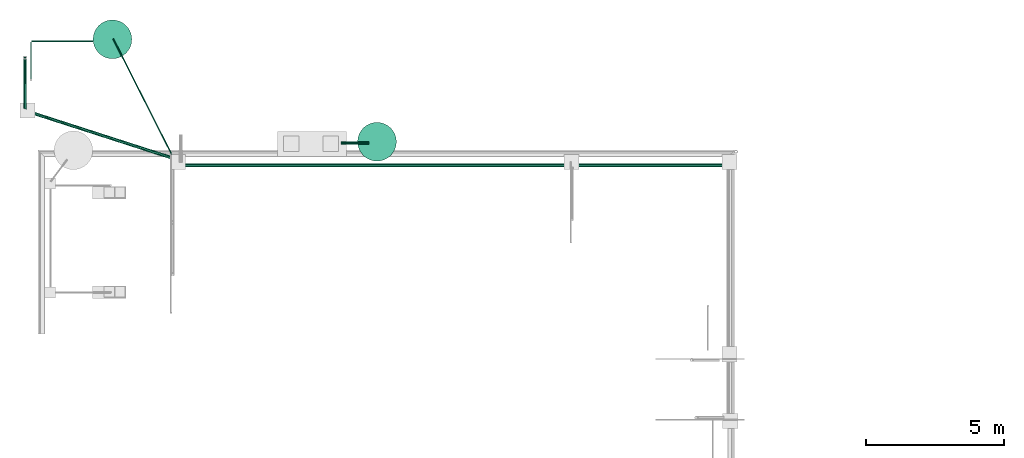
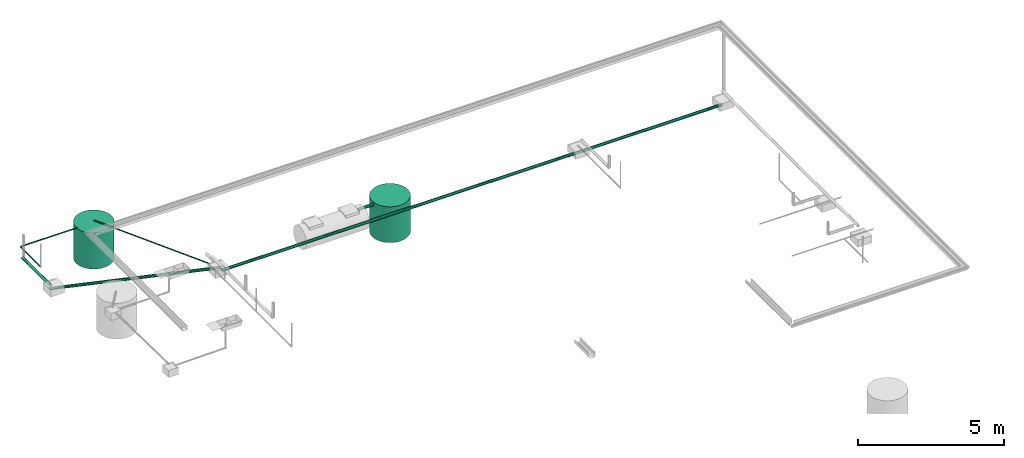
# One storey, part 6 of 15: 7 pipe segments, 2 waste terminals.
"""IFC4X3_ADD2 building model written with IfcOpenShell, lengths in metres."""

from ifc_helpers import new_model, entity, si_unit, converted_unit, frame, origin_with_axes, origin_2d_with_axis, place, context, subcontext, project, spatial, circle, hollow_circle, extrude, clip, halfspace, material, material_profile, profile_set, profile_usage, type_object, element, save


model = new_model("IFC4X3_ADD2")

# Units and contexts
model_context = context("Model", 3, precision=1e-05, world=origin_with_axes())
plan_context = context("Plan", 2, precision=1e-05, world=origin_2d_with_axis())
body_context = subcontext(model_context, "Body", "Model", "MODEL_VIEW")
ifc_project = project(units=[si_unit("VOLUMEUNIT", "CUBIC_METRE"), si_unit("LENGTHUNIT", "METRE"), converted_unit("PLANEANGLEUNIT", "degree", entity("IfcReal", 0.0174532925199433), si_unit("PLANEANGLEUNIT", "RADIAN"), dimensions=[0, 0, 0, 0, 0, 0, 0]), si_unit("AREAUNIT", "SQUARE_METRE")], contexts=[model_context, plan_context])

# Site, building, storey
site_placement = place(None, origin_with_axes())
site = spatial("IfcSite", under=ifc_project, at=site_placement)
building_placement = place(site_placement, origin_with_axes())
building = spatial("IfcBuilding", under=site, at=building_placement, Name="Building")
storey_placement = place(building_placement, origin_with_axes())
storey = spatial("IfcBuildingStorey", under=building, at=storey_placement, Name="Plumbing")

# Waste terminals
ifc_material_1 = material(Name="Wall")
ifc_material_profile_1 = material_profile(ifc_material_1, circle(Radius=0.699999988079071))
ifc_profile_set_1 = profile_set([ifc_material_profile_1])
ifc_profile_usage_1 = profile_usage(ifc_profile_set_1, cardinal=5)
waste_terminal_type = type_object("IfcWasteTerminalType", Name="1200mm ID", PredefinedType="USERDEFINED", material=ifc_profile_set_1)
waste_terminal_1_placement = place(storey_placement, frame((16.6055736541748, 27.7044715881348, -7.45058059692383e-09), z_axis=(-8.74227552571925e-08, 1.50995816738939e-07, -0.999999999999985), x_axis=(1.62920684942943e-07, 0.999999999999975, 1.50995802528083e-07)))
element("IfcWasteTerminal", 1, at=waste_terminal_1_placement, inside=storey, type_object=waste_terminal_type, material=ifc_profile_usage_1, Name="WasteTerminal", context=body_context, shape_type="SweptSolid", body=[
    extrude(circle(Radius=0.699999988079071), origin_with_axes(), (0.0, 0.0, 1.0), 1.5),
])
ifc_profile_usage_2 = profile_usage(ifc_profile_set_1, cardinal=5)
waste_terminal_2_placement = place(storey_placement, frame((7.02344703674316, 31.4147243499756, 1.19209289550781e-07), z_axis=(-1.50995802528084e-07, -8.74227694680472e-08, -0.999999999999985), x_axis=(-0.999999999999985, 8.74227836789019e-08, 1.50995802528084e-07)))
element("IfcWasteTerminal", 2, at=waste_terminal_2_placement, inside=storey, type_object=waste_terminal_type, material=ifc_profile_usage_2, Name="WasteTerminal", context=body_context, shape_type="SweptSolid", body=[
    extrude(circle(Radius=0.699999988079071), origin_with_axes(), (0.0, 0.0, 1.0), 1.5),
])

# Pipe segments
ifc_material_2 = material()
ifc_material_profile_2 = material_profile(ifc_material_2, hollow_circle(Radius=0.0571499988436699, WallThickness=0.012699999846518))
ifc_profile_set_2 = profile_set([ifc_material_profile_2])
ifc_profile_usage_3 = profile_usage(ifc_profile_set_2)
pipe_segment_type_1 = type_object("IfcPipeSegmentType", Name="4inch Tank", PredefinedType="FLEXIBLESEGMENT", material=ifc_profile_set_2)
pipe_segment_1_placement = place(storey_placement, frame((29.2563171386719, 26.8517551422119, -0.1225526034832), z_axis=(-0.999999999999996, 4.37114202611609e-08, 7.5497901264043e-08), x_axis=(-4.37113882867346e-08, -0.999999999999923, 3.89414395840474e-07)))
element("IfcPipeSegment", 3, at=pipe_segment_1_placement, inside=storey, type_object=pipe_segment_type_1, material=ifc_profile_usage_3, Name="PipeSegment", PredefinedType="FLEXIBLESEGMENT", context=body_context, shape_type="SweptSolid", body=[
    extrude(hollow_circle(Radius=0.0571499988436699, WallThickness=0.012699999846518), origin_with_axes(), (0.0, 0.0, 1.0), 19.7956980029457),
])
ifc_profile_usage_4 = profile_usage(ifc_profile_set_2)
pipe_segment_2_placement = place(storey_placement, frame((3.85473585128784, 28.7807121276855, -0.0307567920535803), z_axis=(8.74228121006121e-08, 0.999999999999993, 7.54979012640428e-08), x_axis=(-0.999999999999921, 8.74227765734689e-08, 3.89414424262182e-07)))
element("IfcPipeSegment", 4, at=pipe_segment_2_placement, inside=storey, type_object=pipe_segment_type_1, material=ifc_profile_usage_4, Name="PipeSegment", PredefinedType="FLEXIBLESEGMENT", context=body_context, shape_type="Clipping", body=[
    clip(extrude(hollow_circle(Radius=0.0571499988436699, WallThickness=0.012699999846518), origin_with_axes(), (0.0, 0.0, 1.0), 2.02640719087022), halfspace(frame((0.148413762450218, -0.091795414686203, 0.162123039364815), z_axis=(0.306696087121964, -4.64804941202601e-07, -0.951807498931885), x_axis=(-1.51552289291917e-06, -0.999999999998852, 0.0)), False)),
])
ifc_profile_usage_5 = profile_usage(ifc_profile_set_2)
pipe_segment_3_placement = place(storey_placement, frame((3.68879437446594, 28.8884391784668, -0.122552156448364), z_axis=(0.951807487910234, -0.306696113372835, 7.54979003897999e-08), x_axis=(0.306696113372813, 0.951807487910165, 3.89414419752881e-07)))
element("IfcPipeSegment", 5, at=pipe_segment_3_placement, inside=storey, type_object=pipe_segment_type_1, material=ifc_profile_usage_5, Name="PipeSegment", PredefinedType="FLEXIBLESEGMENT", context=body_context, shape_type="Clipping", body=[
    clip(extrude(hollow_circle(Radius=0.0571499988436699, WallThickness=0.012699999846518), origin_with_axes(), (0.0, 0.0, 1.0), 6.11946166968216), halfspace(frame((0.895477116107941, -2.91270339403127e-07, -0.174245089292526), z_axis=(-0.306695997714996, 5.80705716402008e-07, -0.95180743932724), x_axis=(1.89342450089812e-06, 0.999999999998207, 0.0)), False)),
])
ifc_profile_usage_6 = profile_usage(ifc_profile_set_2)
pipe_segment_4_placement = place(storey_placement, frame((15.3100614547729, 27.659538269043, -0.122552245855331), z_axis=(0.999999999999986, -1.62920699153799e-07, 4.37113882867373e-08), x_axis=(1.62920684942932e-07, 0.999999999999911, 3.8941436741876e-07)))
element("IfcPipeSegment", 6, at=pipe_segment_4_placement, inside=storey, type_object=pipe_segment_type_1, material=ifc_profile_usage_6, Name="PipeSegment", PredefinedType="FLEXIBLESEGMENT", context=body_context, shape_type="SweptSolid", body=[
    extrude(hollow_circle(Radius=0.0571499988436699, WallThickness=0.012699999846518), origin_with_axes(), (0.0, 0.0, 1.0), 1.0),
])
ifc_material_profile_3 = material_profile(ifc_material_1, hollow_circle(Radius=0.0253999996930361, WallThickness=0.0020000000949949))
ifc_profile_set_3 = profile_set([ifc_material_profile_3])
ifc_profile_usage_7 = profile_usage(ifc_profile_set_3)
ifc_material_profile_4 = material_profile(ifc_material_1, hollow_circle(Radius=0.0253999996930361, WallThickness=0.0020000000949949))
ifc_profile_set_4 = profile_set([ifc_material_profile_4])
pipe_segment_type_2 = type_object("IfcPipeSegmentType", Name="2inch-bath outlet", PredefinedType="FLEXIBLESEGMENT", material=ifc_profile_set_4)
pipe_segment_5_placement = place(storey_placement, frame((9.18791961669922, 27.2065963745117, 0.0252151321619749), z_axis=(-0.451274655704666, 0.892385110318762, 7.5497900008421e-08), x_axis=(-0.892385110318697, -0.451274655704633, 3.89414417785747e-07)))
element("IfcPipeSegment", 7, at=pipe_segment_5_placement, inside=storey, type_object=pipe_segment_type_2, material=ifc_profile_usage_7, Name="PipeSegment", context=body_context, shape_type="Clipping", body=[
    clip(extrude(hollow_circle(Radius=0.0253999996930361, WallThickness=0.0020000000949949), origin_with_axes(), (0.0, 0.0, 1.0), 4.74020746614029), halfspace(frame((0.531505584716797, -1.27795146909193e-07, -1.00024127960205), z_axis=(-0.892385125160217, -7.83650300206773e-09, -0.451274484395981), x_axis=(-8.78152580217064e-09, 1.0, 0.0)), False)),
])
ifc_profile_usage_8 = profile_usage(ifc_profile_set_3)
pipe_segment_6_placement = place(storey_placement, frame((4.0724983215332, 29.941032409668, 0.0252149868756533), z_axis=(-1.50995774106375e-07, 0.999999999999986, 7.54979012640422e-08), x_axis=(-0.999999999999913, -1.50995802528073e-07, 3.89414424262179e-07)))
element("IfcPipeSegment", 8, at=pipe_segment_6_placement, inside=storey, type_object=pipe_segment_type_2, material=ifc_profile_usage_8, Name="PipeSegment", context=body_context, shape_type="SweptSolid", body=[
    extrude(hollow_circle(Radius=0.0253999996930361, WallThickness=0.0020000000949949), origin_with_axes(), (0.0, 0.0, 1.0), 1.37796593610963),
])
ifc_profile_usage_9 = profile_usage(ifc_profile_set_3)
pipe_segment_7_placement = place(storey_placement, frame((4.09789848327637, 31.3443984985352, 0.0252149850130081), z_axis=(0.999999999999997, -1.19249099483909e-08, 7.54979012640431e-08), x_axis=(1.19248806385021e-08, 0.999999999999924, 3.89414395840474e-07)))
element("IfcPipeSegment", 9, at=pipe_segment_7_placement, inside=storey, type_object=pipe_segment_type_2, material=ifc_profile_usage_9, Name="PipeSegment", context=body_context, shape_type="SweptSolid", body=[
    extrude(hollow_circle(Radius=0.0253999996930361, WallThickness=0.0020000000949949), origin_with_axes(), (0.0, 0.0, 1.0), 2.22750566817911),
])

save(model, "model.ifc")
